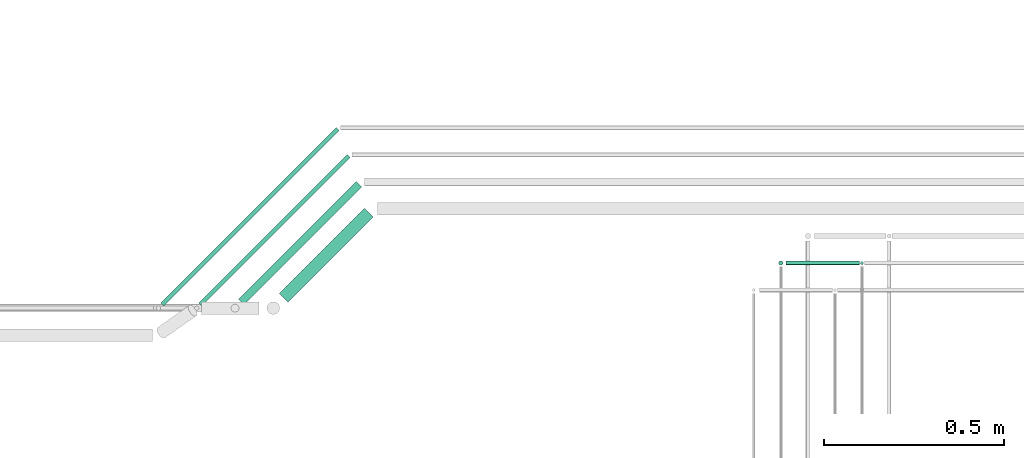
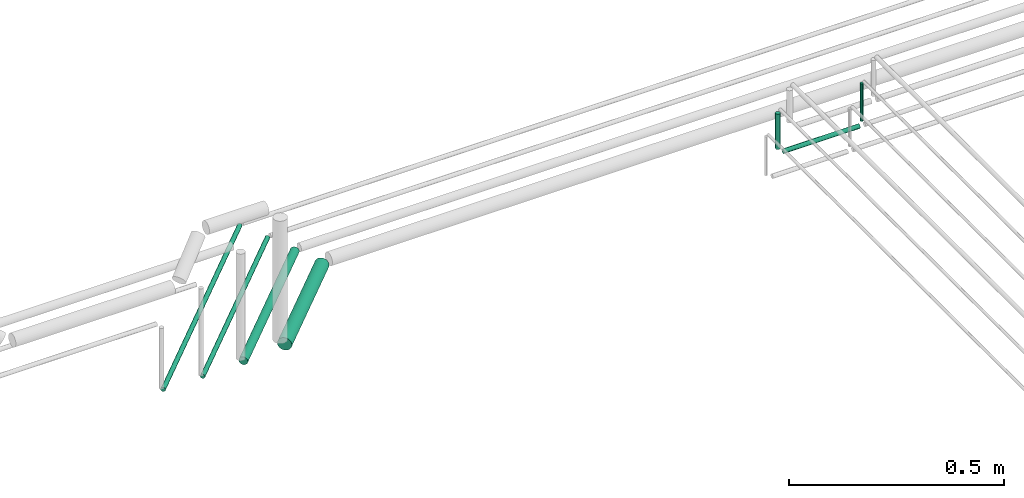
# One storey, part 189 of 331: 7 flow segments.
"""IFC2X3 building model written with IfcOpenShell, lengths in millimetres."""

from ifc_helpers import new_model, entity, si_unit, converted_unit, derived_unit, direction, frame, frame_2d, origin, origin_2d_with_axis, place, context, subcontext, project, spatial, circle, extrude, type_object, element, save


model = new_model("IFC2X3")

# Units and contexts
model_context = context("Model", 3, precision=0.01, world=origin(), true_north=direction((6.12303176911189e-17, 1.0)))
body_context = subcontext(model_context, "Body", "Model", "MODEL_VIEW")
ifc_project = project(units=[si_unit("LENGTHUNIT", "METRE", prefix="MILLI"), si_unit("AREAUNIT", "SQUARE_METRE"), si_unit("VOLUMEUNIT", "CUBIC_METRE"), converted_unit("PLANEANGLEUNIT", "DEGREE", entity("IfcRatioMeasure", 0.0174532925199433), si_unit("PLANEANGLEUNIT", "RADIAN"), dimensions=[0, 0, 0, 0, 0, 0, 0]), si_unit("MASSUNIT", "GRAM", prefix="KILO"), derived_unit("MASSDENSITYUNIT", [(si_unit("MASSUNIT", "GRAM", prefix="KILO"), 1), (si_unit("LENGTHUNIT", "METRE"), -3)]), derived_unit("MOMENTOFINERTIAUNIT", [(si_unit("LENGTHUNIT", "METRE"), 4)]), si_unit("TIMEUNIT", "SECOND"), si_unit("FREQUENCYUNIT", "HERTZ"), si_unit("THERMODYNAMICTEMPERATUREUNIT", "DEGREE_CELSIUS"), derived_unit("THERMALTRANSMITTANCEUNIT", [(si_unit("MASSUNIT", "GRAM", prefix="KILO"), 1), (si_unit("THERMODYNAMICTEMPERATUREUNIT", "KELVIN"), -1), (si_unit("TIMEUNIT", "SECOND"), -3)]), derived_unit("VOLUMETRICFLOWRATEUNIT", [(si_unit("LENGTHUNIT", "METRE"), 3), (si_unit("TIMEUNIT", "SECOND"), -1)]), derived_unit("MASSFLOWRATEUNIT", [(si_unit("MASSUNIT", "GRAM", prefix="KILO"), 1), (si_unit("TIMEUNIT", "SECOND"), -1)]), derived_unit("ROTATIONALFREQUENCYUNIT", [(si_unit("TIMEUNIT", "SECOND"), -1)]), si_unit("ELECTRICCURRENTUNIT", "AMPERE"), si_unit("ELECTRICVOLTAGEUNIT", "VOLT"), si_unit("POWERUNIT", "WATT"), si_unit("FORCEUNIT", "NEWTON", prefix="KILO"), si_unit("ILLUMINANCEUNIT", "LUX"), si_unit("LUMINOUSFLUXUNIT", "LUMEN"), si_unit("LUMINOUSINTENSITYUNIT", "CANDELA"), derived_unit("USERDEFINED", [(si_unit("MASSUNIT", "GRAM", prefix="KILO"), -1), (si_unit("LENGTHUNIT", "METRE"), -2), (si_unit("TIMEUNIT", "SECOND"), 3), (si_unit("LUMINOUSFLUXUNIT", "LUMEN"), 1)]), derived_unit("LINEARVELOCITYUNIT", [(si_unit("LENGTHUNIT", "METRE"), 1), (si_unit("TIMEUNIT", "SECOND"), -1)]), si_unit("PRESSUREUNIT", "PASCAL"), derived_unit("USERDEFINED", [(si_unit("LENGTHUNIT", "METRE"), -2), (si_unit("MASSUNIT", "GRAM", prefix="KILO"), 1), (si_unit("TIMEUNIT", "SECOND"), -2)]), derived_unit("LINEARFORCEUNIT", [(si_unit("MASSUNIT", "GRAM", prefix="KILO"), 1), (si_unit("LENGTHUNIT", "METRE"), 1), (si_unit("TIMEUNIT", "SECOND"), -2), (si_unit("LENGTHUNIT", "METRE"), -1)]), derived_unit("PLANARFORCEUNIT", [(si_unit("MASSUNIT", "GRAM", prefix="KILO"), 1), (si_unit("LENGTHUNIT", "METRE"), 1), (si_unit("TIMEUNIT", "SECOND"), -2), (si_unit("LENGTHUNIT", "METRE"), -2)])], contexts=[model_context])

# Site, building, storey
site_placement = place(None, frame((0.0, -0.00077364408347762, 0.0)))
site = spatial("IfcSite", under=ifc_project, at=site_placement, CompositionType="ELEMENT")
building_placement = place(site_placement, origin())
building = spatial("IfcBuilding", under=site, at=building_placement, CompositionType="ELEMENT")
storey_placement = place(building_placement, origin())
storey = spatial("IfcBuildingStorey", under=building, at=storey_placement, CompositionType="ELEMENT", Elevation=0.0)

# Flow segments
pipe_segment_type = type_object("IfcPipeSegmentType", PredefinedType="NOTDEFINED")
flow_segment_1_placement = place(storey_placement, frame((43559.0420767625, 9467.40472776405, 18442.4047277642)))
element("IfcFlowSegment", 1, at=flow_segment_1_placement, inside=storey, type_object=pipe_segment_type, context=body_context, shape_type="SweptSolid", body=[
    extrude(circle(Radius=6.0, at=frame_2d((1.08286712929839e-12, 0.0), x_axis=(1.0, 0.0))), frame((0.0, 7.5952722359167, 7.5952722359167), z_axis=(1.0, 0.0, 0.0), x_axis=(0.0, 1.0, 0.0)), (0.0, 0.0, 1.0), 204.000000000014),
])
flow_segment_2_placement = place(storey_placement, frame((43537.4468045266, 9467.40472776405, 18464.0)))
element("IfcFlowSegment", 2, at=flow_segment_2_placement, inside=storey, type_object=pipe_segment_type, context=body_context, shape_type="SweptSolid", body=[
    extrude(circle(Radius=6.0, at=origin_2d_with_axis()), frame((7.59527223591454, 7.59527223591562, 0.0)), (0.0, 0.0, 1.0), 99.9999999998841),
])
flow_segment_3_placement = place(building_placement, frame((43764.4468045266, 9469.40472776405, 18463.0)))
element("IfcFlowSegment", 3, at=flow_segment_3_placement, inside=storey, type_object=pipe_segment_type, context=body_context, shape_type="SweptSolid", body=[
    extrude(circle(Radius=4.0, at=origin_2d_with_axis()), frame((5.59527223591499, 5.59527223591607, 0.0), z_axis=(0.0, 0.0, 1.0), x_axis=(-1.0, 0.0, 0.0)), (0.0, 0.0, 1.0), 106.99999999993),
])
flow_segment_4_placement = place(storey_placement, frame((42152.6117821722, 9364.31463034117, 18430.9047277641)))
element("IfcFlowSegment", 4, at=flow_segment_4_placement, inside=storey, type_object=pipe_segment_type, context=body_context, shape_type="SweptSolid", body=[
    extrude(circle(Radius=17.5, at=origin_2d_with_axis()), frame((13.9696409066848, 13.9696409066837, 19.0952722359163), z_axis=(0.707106781186531, 0.707106781186564, 0.0), x_axis=(-0.707106781186564, 0.707106781186531, 0.0)), (0.0, 0.0, 1.0), 334.908729651997),
])
flow_segment_5_placement = place(storey_placement, frame((42039.8282505725, 9357.59711591944, 18437.4047277679)))
element("IfcFlowSegment", 5, at=flow_segment_5_placement, inside=storey, type_object=pipe_segment_type, context=body_context, shape_type="SweptSolid", body=[
    extrude(circle(Radius=11.0, at=origin_2d_with_axis()), frame((9.37344682897115, 9.37344682897006, 12.5952722359156), z_axis=(0.707106781186528, 0.707106781186567, 0.0), x_axis=(-0.707106781186567, 0.707106781186528, 0.0)), (0.0, 0.0, 1.0), 461.974746830621),
])
flow_segment_6_placement = place(storey_placement, frame((41930.2266994886, 9354.06158201352, 18442.4047277585)))
element("IfcFlowSegment", 6, at=flow_segment_6_placement, inside=storey, type_object=pipe_segment_type, context=body_context, shape_type="SweptSolid", body=[
    extrude(circle(Radius=6.0, at=frame_2d((0.0, 2.16573425859679e-12), x_axis=(1.0, 0.0))), frame((5.83791292303222, 5.83791292303222, 7.59527223591454), z_axis=(0.707106781186549, 0.707106781186546, 0.0), x_axis=(-0.707106781186546, 0.707106781186549, 0.0)), (0.0, 0.0, 1.0), 582.040764008615),
])
flow_segment_7_placement = place(storey_placement, frame((41824.1606823107, 9354.0615820136, 18442.4047277609)))
element("IfcFlowSegment", 7, at=flow_segment_7_placement, inside=storey, type_object=pipe_segment_type, context=body_context, shape_type="SweptSolid", body=[
    extrude(circle(Radius=6.0, at=origin_2d_with_axis()), frame((5.83791292303222, 5.83791292303222, 7.5952722359167), z_axis=(0.707106781186546, 0.707106781186549, 0.0), x_axis=(-0.707106781186549, 0.707106781186546, 0.0)), (0.0, 0.0, 1.0), 688.106781186477),
])

save(model, "model.ifc")
